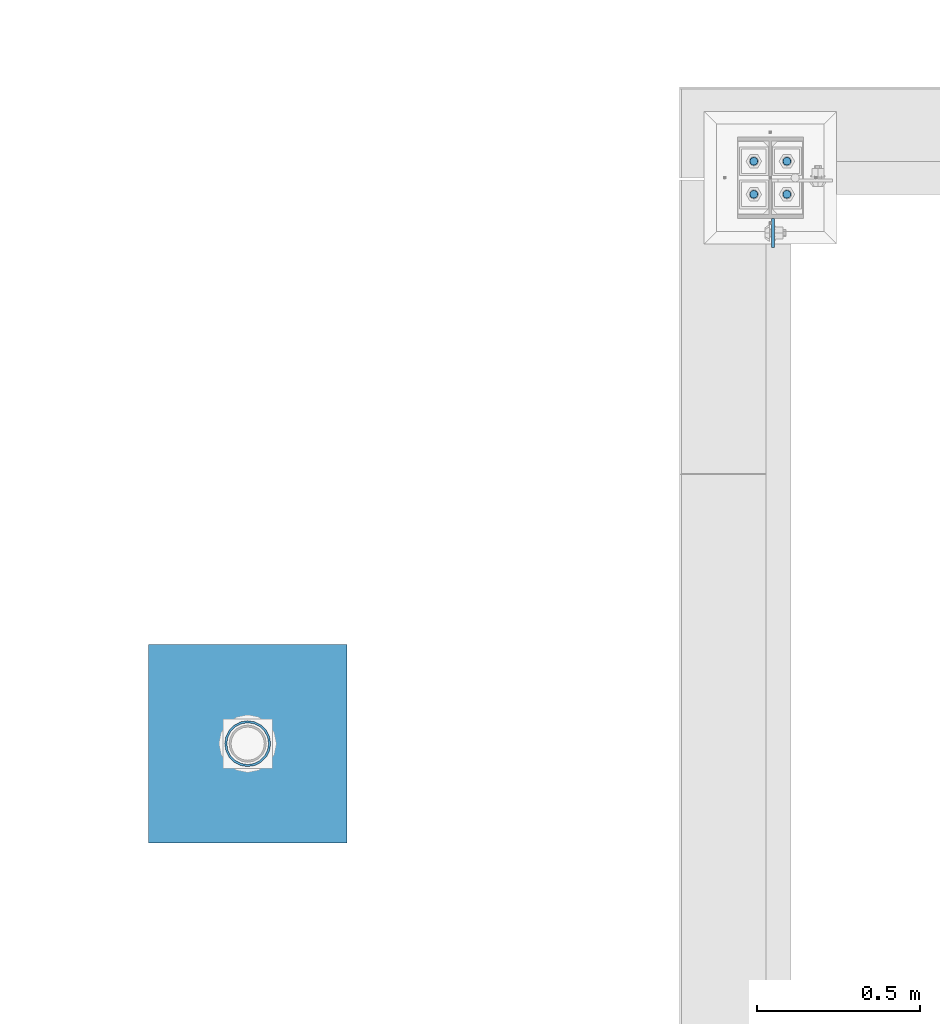
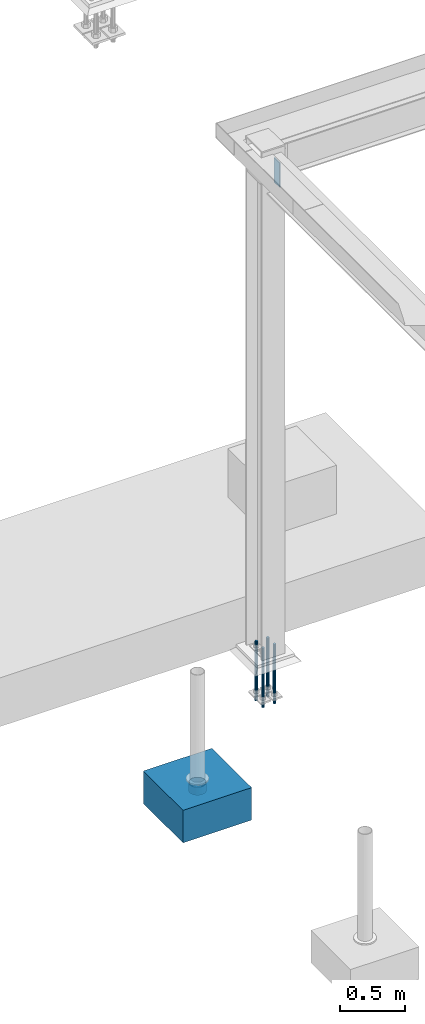
# One storey, part 1505 of 3843: 7 columns, 4 elements without a shape of their own.
"""IFC2X3 building model written with IfcOpenShell, lengths in millimetres."""

from ifc_helpers import new_model, si_unit, frame, origin_with_axes, place, context, subcontext, project, spatial, faceted_brep, material, type_object, element, aggregate, save


model = new_model("IFC2X3")

# Units and contexts
model_context = context("Model", 3, precision=1e-05, world=origin_with_axes())
body_context = subcontext(model_context, "Body", "Model", "MODEL_VIEW")
ifc_project = project(units=[si_unit("LENGTHUNIT", "METRE", prefix="MILLI"), si_unit("AREAUNIT", "SQUARE_METRE"), si_unit("VOLUMEUNIT", "CUBIC_METRE"), si_unit("MASSUNIT", "GRAM", prefix="KILO"), si_unit("TIMEUNIT", "SECOND"), si_unit("PLANEANGLEUNIT", "RADIAN"), si_unit("SOLIDANGLEUNIT", "STERADIAN"), si_unit("THERMODYNAMICTEMPERATUREUNIT", "DEGREE_CELSIUS"), si_unit("LUMINOUSINTENSITYUNIT", "LUMEN")], contexts=[model_context])

# Site, building, storey
site_placement = place(None, origin_with_axes())
site = spatial("IfcSite", under=ifc_project, at=site_placement, CompositionType="ELEMENT")
building_placement = place(site_placement, origin_with_axes())
building = spatial("IfcBuilding", under=site, at=building_placement, Name="Undefined", CompositionType="ELEMENT")
storey_placement = place(building_placement, origin_with_axes())
storey = spatial("IfcBuildingStorey", under=building, at=storey_placement, Name="Undefined", CompositionType="ELEMENT", Elevation=0.0)

# Assembly, column
assembly_1_placement = place(storey_placement, origin_with_axes())
assembly_1 = element("IfcElementAssembly", 1, at=assembly_1_placement, inside=storey, Name="PLATE", AssemblyPlace="NOTDEFINED", PredefinedType="RIGID_FRAME")
ifc_material_1 = material()
column_type_1 = type_object("IfcColumnType", Name="PIPE5SCH40", PredefinedType="NOTDEFINED")
column_1_placement = place(assembly_1_placement, frame((31617.0325124562, 32106.6249086857, 30378.4), z_axis=(-1.0, 0.0, 0.0), x_axis=(0.0, 0.0, 1.0)))
column_1 = element("IfcColumn", 2, at=column_1_placement, type_object=column_type_1, material=ifc_material_1, Name="PIPE_SLEEVE", ObjectType="PIPE5SCH40", context=body_context, shape_type="Brep", body=[
    faceted_brep([(0.0, -64.0587999999998, 0.0), (0.0, -60.9235391660477, 19.7952578392724), (76.2000000000007, -60.9235391660477, 19.7952578392724), (76.2000000000007, -64.0587999999998, 0.0), (0.0, -51.8246578392655, 37.6528179195593), (76.2000000000007, -51.8246578392655, 37.6528179195593), (0.0, -37.6528179195529, 51.8246578392718), (76.2000000000007, -37.6528179195529, 51.8246578392718), (0.0, -19.795257839266, 60.9235391660477), (76.2000000000007, -19.795257839266, 60.9235391660477), (0.0, 0.0, 64.0587999999989), (76.2000000000007, 0.0, 64.0587999999989), (0.0, 19.795257839266, 60.9235391660477), (76.2000000000007, 19.795257839266, 60.9235391660477), (0.0, 37.6528179195529, 51.8246578392718), (76.2000000000007, 37.6528179195529, 51.8246578392718), (0.0, 51.8246578392655, 37.6528179195593), (76.2000000000007, 51.8246578392655, 37.6528179195593), (0.0, 60.9235391660477, 19.7952578392724), (76.2000000000007, 60.9235391660477, 19.7952578392724), (0.0, 64.0587999999998, 0.0), (76.2000000000007, 64.0587999999998, 0.0), (0.0, 60.9235391660477, -19.7952578392724), (76.2000000000007, 60.9235391660477, -19.7952578392724), (0.0, 51.8246578392655, -37.6528179195593), (76.2000000000007, 51.8246578392655, -37.6528179195593), (0.0, 37.6528179195529, -51.8246578392718), (76.2000000000007, 37.6528179195529, -51.8246578392718), (0.0, 19.795257839266, -60.9235391660477), (76.2000000000007, 19.795257839266, -60.9235391660477), (0.0, 0.0, -64.0587999999989), (76.2000000000007, 0.0, -64.0587999999989), (0.0, -19.795257839266, -60.9235391660477), (76.2000000000007, -19.795257839266, -60.9235391660477), (0.0, -37.6528179195529, -51.8246578392718), (76.2000000000007, -37.6528179195529, -51.8246578392718), (0.0, -51.8246578392655, -37.6528179195593), (76.2000000000007, -51.8246578392655, -37.6528179195593), (0.0, -60.9235391660477, -19.7952578392724), (76.2000000000007, -60.9235391660477, -19.7952578392724), (0.0, -70.6120000000001, 0.0), (0.0, -67.1560027286332, -21.8203080068051), (76.2000000000007, -67.1560027286332, -21.8203080068051), (76.2000000000007, -70.6120000000001, 0.0), (0.0, -57.1263080068038, -41.5046922348702), (76.2000000000007, -57.1263080068038, -41.5046922348702), (0.0, -41.5046922348765, -57.126308006802), (76.2000000000007, -41.5046922348765, -57.126308006802), (0.0, -21.8203080068042, -67.1560027286323), (76.2000000000007, -21.8203080068042, -67.1560027286323), (0.0, 0.0, -70.6119999999937), (76.2000000000007, 0.0, -70.6119999999937), (0.0, 21.8203080068042, -67.1560027286323), (76.2000000000007, 21.8203080068042, -67.1560027286323), (0.0, 41.5046922348765, -57.126308006802), (76.2000000000007, 41.5046922348765, -57.126308006802), (0.0, 57.1263080068038, -41.5046922348702), (76.2000000000007, 57.1263080068038, -41.5046922348702), (0.0, 67.1560027286332, -21.8203080068051), (76.2000000000007, 67.1560027286332, -21.8203080068051), (0.0, 70.6120000000001, 0.0), (76.2000000000007, 70.6120000000001, 0.0), (0.0, 67.1560027286332, 21.8203080068051), (76.2000000000007, 67.1560027286332, 21.8203080068051), (0.0, 57.1263080068038, 41.5046922348702), (76.2000000000007, 57.1263080068038, 41.5046922348702), (0.0, 41.5046922348765, 57.126308006802), (76.2000000000007, 41.5046922348765, 57.126308006802), (0.0, 21.8203080068042, 67.1560027286323), (76.2000000000007, 21.8203080068042, 67.1560027286323), (0.0, 0.0, 70.6119999999937), (76.2000000000007, 0.0, 70.6119999999937), (0.0, -21.8203080068042, 67.1560027286323), (76.2000000000007, -21.8203080068042, 67.1560027286323), (0.0, -41.5046922348765, 57.126308006802), (76.2000000000007, -41.5046922348765, 57.126308006802), (0.0, -57.1263080068038, 41.5046922348702), (76.2000000000007, -57.1263080068038, 41.5046922348702), (0.0, -67.1560027286332, 21.8203080068051), (76.2000000000007, -67.1560027286332, 21.8203080068051)], [[[0, 1, 2, 3]], [[1, 4, 5, 2]], [[4, 6, 7, 5]], [[6, 8, 9, 7]], [[8, 10, 11, 9]], [[10, 12, 13, 11]], [[12, 14, 15, 13]], [[14, 16, 17, 15]], [[16, 18, 19, 17]], [[18, 20, 21, 19]], [[20, 22, 23, 21]], [[22, 24, 25, 23]], [[24, 26, 27, 25]], [[26, 28, 29, 27]], [[28, 30, 31, 29]], [[30, 32, 33, 31]], [[32, 34, 35, 33]], [[34, 36, 37, 35]], [[36, 38, 39, 37]], [[38, 0, 3, 39]], [[40, 41, 42, 43]], [[41, 44, 45, 42]], [[44, 46, 47, 45]], [[46, 48, 49, 47]], [[48, 50, 51, 49]], [[50, 52, 53, 51]], [[52, 54, 55, 53]], [[54, 56, 57, 55]], [[56, 58, 59, 57]], [[58, 60, 61, 59]], [[60, 62, 63, 61]], [[62, 64, 65, 63]], [[64, 66, 67, 65]], [[66, 68, 69, 67]], [[68, 70, 71, 69]], [[70, 72, 73, 71]], [[72, 74, 75, 73]], [[74, 76, 77, 75]], [[76, 78, 79, 77]], [[78, 40, 43, 79]], [[45, 47, 49, 51, 53, 55, 57, 59, 61, 63, 65, 67, 69, 71, 73, 75, 77, 79, 43, 42], [5, 7, 9, 11, 13, 15, 17, 19, 21, 23, 25, 27, 29, 31, 33, 35, 37, 39, 3, 2]], [[78, 76, 74, 72, 70, 68, 66, 64, 62, 60, 58, 56, 54, 52, 50, 48, 46, 44, 41, 40], [38, 36, 34, 32, 30, 28, 26, 24, 22, 20, 18, 16, 14, 12, 10, 8, 6, 4, 1, 0]]]),
])
aggregate(assembly_1, [column_1])

assembly_2_placement = place(storey_placement, origin_with_axes())
assembly_2 = element("IfcElementAssembly", 3, at=assembly_2_placement, inside=storey, Name="CONC_COL.", AssemblyPlace="NOTDEFINED", PredefinedType="REINFORCEMENT_UNIT")
ifc_material_2 = material(Name="CONCRETE/3000")
column_type_2 = type_object("IfcColumnType", PredefinedType="NOTDEFINED")
column_2_placement = place(assembly_2_placement, frame((31617.0325124562, 32106.6249086857, 30175.2), z_axis=(-1.0, 0.0, 0.0), x_axis=(0.0, 0.0, 1.0)))
column_2 = element("IfcColumn", 4, at=column_2_placement, type_object=column_type_2, material=ifc_material_2, Name="CONC_COL.", context=body_context, shape_type="Brep", body=[
    faceted_brep([(0.0, 304.8, -304.800000000003), (0.0, 304.8, 304.800000000003), (304.799999999999, 304.8, 304.800000000003), (304.799999999999, 304.8, -304.800000000003), (0.0, -304.8, 304.800000000003), (304.799999999999, -304.8, 304.800000000003), (0.0, -304.8, -304.800000000003), (304.799999999999, -304.8, -304.800000000003)], [[[0, 1, 2, 3]], [[1, 4, 5, 2]], [[4, 6, 7, 5]], [[6, 0, 3, 7]], [[5, 7, 3, 2]], [[6, 4, 1, 0]]]),
])
aggregate(assembly_2, [column_2])

# Assembly, columns
assembly_3_placement = place(storey_placement, origin_with_axes())
assembly_3 = element("IfcElementAssembly", 5, at=assembly_3_placement, inside=storey, Name="TEMPLATE", AssemblyPlace="NOTDEFINED", PredefinedType="RIGID_FRAME")
ifc_material_3 = material(Name="Undefined/F1554-GR.55")
column_type_3 = type_object("IfcColumnType", PredefinedType="NOTDEFINED")
column_3_placement = place(assembly_3_placement, frame((33172.4, 33794.7, 30022.8), z_axis=(0.0, -1.0, 0.0), x_axis=(0.0, 0.0, -1.0)))
column_3 = element("IfcColumn", 6, at=column_3_placement, type_object=column_type_3, material=ifc_material_3, Name="ANCHOR_ROD", context=body_context, shape_type="Brep", body=[
    faceted_brep([(-127.0, -10.3923048454162, 6.0), (-127.0, -6.0, 10.3923048454126), (-127.0, 0.0, 12.0), (-127.0, 6.0, 10.3923048454126), (-127.0, 10.3923048454162, 6.0), (-127.0, 12.0, 0.0), (-127.0, 10.3923048454162, -6.0), (-127.0, 6.0, -10.3923048454126), (-127.0, 0.0, -12.0), (-127.0, -6.0, -10.3923048454126), (-127.0, -10.3923048454162, -6.0), (-127.0, -12.0, 0.0), (0.0, 12.0, 0.0), (0.0, 10.3923048454162, -6.0), (0.0, 6.0, -10.3923048454126), (0.0, 0.0, -12.0), (0.0, -6.0, -10.3923048454126), (0.0, -10.3923048454162, -6.0), (0.0, -12.0, 0.0), (0.0, -10.3923048454162, 6.0), (0.0, -6.0, 10.3923048454126), (0.0, 0.0, 12.0), (0.0, 6.0, 10.3923048454126), (0.0, 10.3923048454162, 6.0), (0.0, -10.9985226280696, 6.34999999999854), (0.0, -6.35000000000582, 10.9985226280623), (0.0, 0.0, 12.6999999999971), (0.0, 6.35000000000582, 10.9985226280623), (0.0, 10.9985226280696, 6.34999999999854), (0.0, 12.6999999999971, 0.0), (0.0, 10.9985226280696, -6.34999999999854), (0.0, 6.35000000000582, -10.9985226280623), (0.0, 0.0, -12.6999999999971), (0.0, -6.35000000000582, -10.9985226280623), (0.0, -10.9985226280696, -6.34999999999854), (0.0, -12.6999999999971, 0.0), (304.799999999999, -12.6999999999971, 0.0), (304.799999999999, -10.9985226280623, 6.35000000000036), (304.799999999999, -6.34999999999854, 10.9985226280623), (304.799999999999, 0.0, 12.7000000000007), (304.799999999999, 6.34999999999854, 10.9985226280623), (304.799999999999, 10.9985226280623, 6.35000000000036), (304.799999999999, 12.6999999999971, 0.0), (304.799999999999, 10.9985226280623, -6.35000000000036), (304.799999999999, 6.34999999999854, -10.9985226280623), (304.799999999999, 0.0, -12.7000000000007), (304.799999999999, -6.34999999999854, -10.9985226280623), (304.799999999999, -10.9985226280623, -6.35000000000036), (304.799999999999, -6.0, 10.3923048454126), (304.799999999999, 0.0, 12.0), (304.799999999999, 6.0, 10.3923048454126), (304.799999999999, 10.3923048454162, 6.0), (304.799999999999, 12.0, 0.0), (304.799999999999, 10.3923048454162, -6.0), (304.799999999999, 6.0, -10.3923048454126), (304.799999999999, 0.0, -12.0), (304.799999999999, -6.0, -10.3923048454126), (304.799999999999, -10.3923048454162, -6.0), (304.799999999999, -12.0, 0.0), (304.799999999999, -10.3923048454162, 6.0), (431.799999999999, -6.0, -10.3923048454126), (431.799999999999, 0.0, -12.0), (431.799999999999, 6.0, -10.3923048454126), (431.799999999999, 10.3923048454162, -6.0), (431.799999999999, 12.0, 0.0), (431.799999999999, 10.3923048454162, 6.0), (431.799999999999, 6.0, 10.3923048454126), (431.799999999999, 0.0, 12.0), (431.799999999999, -6.0, 10.3923048454126), (431.799999999999, -10.3923048454162, 6.0), (431.799999999999, -12.0, 0.0), (431.799999999999, -10.3923048454162, -6.0)], [[[0, 1, 2, 3, 4, 5, 6, 7, 8, 9, 10, 11]], [[6, 5, 12, 13]], [[7, 6, 13, 14]], [[8, 7, 14, 15]], [[9, 8, 15, 16]], [[10, 9, 16, 17]], [[11, 10, 17, 18]], [[0, 11, 18, 19]], [[1, 0, 19, 20]], [[2, 1, 20, 21]], [[3, 2, 21, 22]], [[4, 3, 22, 23]], [[5, 4, 23, 12]], [[24, 25, 26, 27, 28, 29, 30, 31, 32, 33, 34, 35], [22, 21, 20, 19, 18, 17, 16, 15, 14, 13, 12, 23]], [[24, 35, 36, 37]], [[25, 24, 37, 38]], [[26, 25, 38, 39]], [[27, 26, 39, 40]], [[28, 27, 40, 41]], [[29, 28, 41, 42]], [[30, 29, 42, 43]], [[31, 30, 43, 44]], [[32, 31, 44, 45]], [[33, 32, 45, 46]], [[34, 33, 46, 47]], [[35, 34, 47, 36]], [[46, 45, 44, 43, 42, 41, 40, 39, 38, 37, 36, 47], [48, 49, 50, 51, 52, 53, 54, 55, 56, 57, 58, 59]], [[60, 61, 62, 63, 64, 65, 66, 67, 68, 69, 70, 71]], [[68, 67, 49, 48]], [[69, 68, 48, 59]], [[70, 69, 59, 58]], [[71, 70, 58, 57]], [[60, 71, 57, 56]], [[61, 60, 56, 55]], [[62, 61, 55, 54]], [[63, 62, 54, 53]], [[64, 63, 53, 52]], [[65, 64, 52, 51]], [[66, 65, 51, 50]], [[67, 66, 50, 49]]]),
])
column_4_placement = place(assembly_3_placement, frame((33274.0, 33794.7, 30022.8), z_axis=(0.0, 1.0, 0.0), x_axis=(0.0, 0.0, -1.0)))
column_4 = element("IfcColumn", 7, at=column_4_placement, type_object=column_type_3, material=ifc_material_3, Name="ANCHOR_ROD", context=body_context, shape_type="Brep", body=[
    faceted_brep([(-127.0, -10.3923048454162, 6.0), (-127.0, -6.0, 10.3923048454126), (-127.0, 0.0, 12.0), (-127.0, 6.0, 10.3923048454126), (-127.0, 10.3923048454162, 6.0), (-127.0, 12.0, 0.0), (-127.0, 10.3923048454162, -6.0), (-127.0, 6.0, -10.3923048454126), (-127.0, 0.0, -12.0), (-127.0, -6.0, -10.3923048454126), (-127.0, -10.3923048454162, -6.0), (-127.0, -12.0, 0.0), (0.0, 12.0, 0.0), (0.0, 10.3923048454162, -6.0), (0.0, 6.0, -10.3923048454126), (0.0, 0.0, -12.0), (0.0, -6.0, -10.3923048454126), (0.0, -10.3923048454162, -6.0), (0.0, -12.0, 0.0), (0.0, -10.3923048454162, 6.0), (0.0, -6.0, 10.3923048454126), (0.0, 0.0, 12.0), (0.0, 6.0, 10.3923048454126), (0.0, 10.3923048454162, 6.0), (0.0, -10.9985226280696, 6.34999999999854), (0.0, -6.35000000000582, 10.9985226280623), (0.0, 0.0, 12.6999999999971), (0.0, 6.35000000000582, 10.9985226280623), (0.0, 10.9985226280696, 6.34999999999854), (0.0, 12.6999999999971, 0.0), (0.0, 10.9985226280696, -6.34999999999854), (0.0, 6.35000000000582, -10.9985226280623), (0.0, 0.0, -12.6999999999971), (0.0, -6.35000000000582, -10.9985226280623), (0.0, -10.9985226280696, -6.34999999999854), (0.0, -12.6999999999971, 0.0), (304.799999999999, -12.6999999999971, 0.0), (304.799999999999, -10.9985226280623, 6.35000000000036), (304.799999999999, -6.34999999999854, 10.9985226280623), (304.799999999999, 0.0, 12.7000000000007), (304.799999999999, 6.34999999999854, 10.9985226280623), (304.799999999999, 10.9985226280623, 6.35000000000036), (304.799999999999, 12.6999999999971, 0.0), (304.799999999999, 10.9985226280623, -6.35000000000036), (304.799999999999, 6.34999999999854, -10.9985226280623), (304.799999999999, 0.0, -12.7000000000007), (304.799999999999, -6.34999999999854, -10.9985226280623), (304.799999999999, -10.9985226280623, -6.35000000000036), (304.799999999999, -6.0, 10.3923048454126), (304.799999999999, 0.0, 12.0), (304.799999999999, 6.0, 10.3923048454126), (304.799999999999, 10.3923048454162, 6.0), (304.799999999999, 12.0, 0.0), (304.799999999999, 10.3923048454162, -6.0), (304.799999999999, 6.0, -10.3923048454126), (304.799999999999, 0.0, -12.0), (304.799999999999, -6.0, -10.3923048454126), (304.799999999999, -10.3923048454162, -6.0), (304.799999999999, -12.0, 0.0), (304.799999999999, -10.3923048454162, 6.0), (431.799999999999, -6.0, -10.3923048454126), (431.799999999999, 0.0, -12.0), (431.799999999999, 6.0, -10.3923048454126), (431.799999999999, 10.3923048454162, -6.0), (431.799999999999, 12.0, 0.0), (431.799999999999, 10.3923048454162, 6.0), (431.799999999999, 6.0, 10.3923048454126), (431.799999999999, 0.0, 12.0), (431.799999999999, -6.0, 10.3923048454126), (431.799999999999, -10.3923048454162, 6.0), (431.799999999999, -12.0, 0.0), (431.799999999999, -10.3923048454162, -6.0)], [[[0, 1, 2, 3, 4, 5, 6, 7, 8, 9, 10, 11]], [[6, 5, 12, 13]], [[7, 6, 13, 14]], [[8, 7, 14, 15]], [[9, 8, 15, 16]], [[10, 9, 16, 17]], [[11, 10, 17, 18]], [[0, 11, 18, 19]], [[1, 0, 19, 20]], [[2, 1, 20, 21]], [[3, 2, 21, 22]], [[4, 3, 22, 23]], [[5, 4, 23, 12]], [[24, 25, 26, 27, 28, 29, 30, 31, 32, 33, 34, 35], [22, 21, 20, 19, 18, 17, 16, 15, 14, 13, 12, 23]], [[24, 35, 36, 37]], [[25, 24, 37, 38]], [[26, 25, 38, 39]], [[27, 26, 39, 40]], [[28, 27, 40, 41]], [[29, 28, 41, 42]], [[30, 29, 42, 43]], [[31, 30, 43, 44]], [[32, 31, 44, 45]], [[33, 32, 45, 46]], [[34, 33, 46, 47]], [[35, 34, 47, 36]], [[46, 45, 44, 43, 42, 41, 40, 39, 38, 37, 36, 47], [48, 49, 50, 51, 52, 53, 54, 55, 56, 57, 58, 59]], [[60, 61, 62, 63, 64, 65, 66, 67, 68, 69, 70, 71]], [[68, 67, 49, 48]], [[69, 68, 48, 59]], [[70, 69, 59, 58]], [[71, 70, 58, 57]], [[60, 71, 57, 56]], [[61, 60, 56, 55]], [[62, 61, 55, 54]], [[63, 62, 54, 53]], [[64, 63, 53, 52]], [[65, 64, 52, 51]], [[66, 65, 51, 50]], [[67, 66, 50, 49]]]),
])
column_5_placement = place(assembly_3_placement, frame((33172.4, 33896.3, 30022.8), z_axis=(0.0, -1.0, 0.0), x_axis=(0.0, 0.0, -1.0)))
column_5 = element("IfcColumn", 8, at=column_5_placement, type_object=column_type_3, material=ifc_material_3, Name="ANCHOR_ROD", context=body_context, shape_type="Brep", body=[
    faceted_brep([(-127.0, -10.3923048454162, 6.0), (-127.0, -6.0, 10.3923048454126), (-127.0, 0.0, 12.0), (-127.0, 6.0, 10.3923048454126), (-127.0, 10.3923048454162, 6.0), (-127.0, 12.0, 0.0), (-127.0, 10.3923048454162, -6.0), (-127.0, 6.0, -10.3923048454126), (-127.0, 0.0, -12.0), (-127.0, -6.0, -10.3923048454126), (-127.0, -10.3923048454162, -6.0), (-127.0, -12.0, 0.0), (0.0, 12.0, 0.0), (0.0, 10.3923048454162, -6.0), (0.0, 6.0, -10.3923048454126), (0.0, 0.0, -12.0), (0.0, -6.0, -10.3923048454126), (0.0, -10.3923048454162, -6.0), (0.0, -12.0, 0.0), (0.0, -10.3923048454162, 6.0), (0.0, -6.0, 10.3923048454126), (0.0, 0.0, 12.0), (0.0, 6.0, 10.3923048454126), (0.0, 10.3923048454162, 6.0), (0.0, -10.9985226280696, 6.34999999999854), (0.0, -6.35000000000582, 10.9985226280623), (0.0, 0.0, 12.6999999999971), (0.0, 6.35000000000582, 10.9985226280623), (0.0, 10.9985226280696, 6.34999999999854), (0.0, 12.6999999999971, 0.0), (0.0, 10.9985226280696, -6.34999999999854), (0.0, 6.35000000000582, -10.9985226280623), (0.0, 0.0, -12.6999999999971), (0.0, -6.35000000000582, -10.9985226280623), (0.0, -10.9985226280696, -6.34999999999854), (0.0, -12.6999999999971, 0.0), (304.799999999999, -12.6999999999971, 0.0), (304.799999999999, -10.9985226280623, 6.35000000000036), (304.799999999999, -6.34999999999854, 10.9985226280623), (304.799999999999, 0.0, 12.7000000000007), (304.799999999999, 6.34999999999854, 10.9985226280623), (304.799999999999, 10.9985226280623, 6.35000000000036), (304.799999999999, 12.6999999999971, 0.0), (304.799999999999, 10.9985226280623, -6.35000000000036), (304.799999999999, 6.34999999999854, -10.9985226280623), (304.799999999999, 0.0, -12.7000000000007), (304.799999999999, -6.34999999999854, -10.9985226280623), (304.799999999999, -10.9985226280623, -6.35000000000036), (304.799999999999, -6.0, 10.3923048454126), (304.799999999999, 0.0, 12.0), (304.799999999999, 6.0, 10.3923048454126), (304.799999999999, 10.3923048454162, 6.0), (304.799999999999, 12.0, 0.0), (304.799999999999, 10.3923048454162, -6.0), (304.799999999999, 6.0, -10.3923048454126), (304.799999999999, 0.0, -12.0), (304.799999999999, -6.0, -10.3923048454126), (304.799999999999, -10.3923048454162, -6.0), (304.799999999999, -12.0, 0.0), (304.799999999999, -10.3923048454162, 6.0), (431.799999999999, -6.0, -10.3923048454126), (431.799999999999, 0.0, -12.0), (431.799999999999, 6.0, -10.3923048454126), (431.799999999999, 10.3923048454162, -6.0), (431.799999999999, 12.0, 0.0), (431.799999999999, 10.3923048454162, 6.0), (431.799999999999, 6.0, 10.3923048454126), (431.799999999999, 0.0, 12.0), (431.799999999999, -6.0, 10.3923048454126), (431.799999999999, -10.3923048454162, 6.0), (431.799999999999, -12.0, 0.0), (431.799999999999, -10.3923048454162, -6.0)], [[[0, 1, 2, 3, 4, 5, 6, 7, 8, 9, 10, 11]], [[6, 5, 12, 13]], [[7, 6, 13, 14]], [[8, 7, 14, 15]], [[9, 8, 15, 16]], [[10, 9, 16, 17]], [[11, 10, 17, 18]], [[0, 11, 18, 19]], [[1, 0, 19, 20]], [[2, 1, 20, 21]], [[3, 2, 21, 22]], [[4, 3, 22, 23]], [[5, 4, 23, 12]], [[24, 25, 26, 27, 28, 29, 30, 31, 32, 33, 34, 35], [22, 21, 20, 19, 18, 17, 16, 15, 14, 13, 12, 23]], [[24, 35, 36, 37]], [[25, 24, 37, 38]], [[26, 25, 38, 39]], [[27, 26, 39, 40]], [[28, 27, 40, 41]], [[29, 28, 41, 42]], [[30, 29, 42, 43]], [[31, 30, 43, 44]], [[32, 31, 44, 45]], [[33, 32, 45, 46]], [[34, 33, 46, 47]], [[35, 34, 47, 36]], [[46, 45, 44, 43, 42, 41, 40, 39, 38, 37, 36, 47], [48, 49, 50, 51, 52, 53, 54, 55, 56, 57, 58, 59]], [[60, 61, 62, 63, 64, 65, 66, 67, 68, 69, 70, 71]], [[68, 67, 49, 48]], [[69, 68, 48, 59]], [[70, 69, 59, 58]], [[71, 70, 58, 57]], [[60, 71, 57, 56]], [[61, 60, 56, 55]], [[62, 61, 55, 54]], [[63, 62, 54, 53]], [[64, 63, 53, 52]], [[65, 64, 52, 51]], [[66, 65, 51, 50]], [[67, 66, 50, 49]]]),
])
column_6_placement = place(assembly_3_placement, frame((33274.0, 33896.3, 30022.8), z_axis=(0.0, 1.0, 0.0), x_axis=(0.0, 0.0, -1.0)))
column_6 = element("IfcColumn", 9, at=column_6_placement, type_object=column_type_3, material=ifc_material_3, Name="ANCHOR_ROD", context=body_context, shape_type="Brep", body=[
    faceted_brep([(-127.0, -10.3923048454162, 6.0), (-127.0, -6.0, 10.3923048454126), (-127.0, 0.0, 12.0), (-127.0, 6.0, 10.3923048454126), (-127.0, 10.3923048454162, 6.0), (-127.0, 12.0, 0.0), (-127.0, 10.3923048454162, -6.0), (-127.0, 6.0, -10.3923048454126), (-127.0, 0.0, -12.0), (-127.0, -6.0, -10.3923048454126), (-127.0, -10.3923048454162, -6.0), (-127.0, -12.0, 0.0), (0.0, 12.0, 0.0), (0.0, 10.3923048454162, -6.0), (0.0, 6.0, -10.3923048454126), (0.0, 0.0, -12.0), (0.0, -6.0, -10.3923048454126), (0.0, -10.3923048454162, -6.0), (0.0, -12.0, 0.0), (0.0, -10.3923048454162, 6.0), (0.0, -6.0, 10.3923048454126), (0.0, 0.0, 12.0), (0.0, 6.0, 10.3923048454126), (0.0, 10.3923048454162, 6.0), (0.0, -10.9985226280696, 6.34999999999854), (0.0, -6.35000000000582, 10.9985226280623), (0.0, 0.0, 12.6999999999971), (0.0, 6.35000000000582, 10.9985226280623), (0.0, 10.9985226280696, 6.34999999999854), (0.0, 12.6999999999971, 0.0), (0.0, 10.9985226280696, -6.34999999999854), (0.0, 6.35000000000582, -10.9985226280623), (0.0, 0.0, -12.6999999999971), (0.0, -6.35000000000582, -10.9985226280623), (0.0, -10.9985226280696, -6.34999999999854), (0.0, -12.6999999999971, 0.0), (304.799999999999, -12.6999999999971, 0.0), (304.799999999999, -10.9985226280623, 6.35000000000036), (304.799999999999, -6.34999999999854, 10.9985226280623), (304.799999999999, 0.0, 12.7000000000007), (304.799999999999, 6.34999999999854, 10.9985226280623), (304.799999999999, 10.9985226280623, 6.35000000000036), (304.799999999999, 12.6999999999971, 0.0), (304.799999999999, 10.9985226280623, -6.35000000000036), (304.799999999999, 6.34999999999854, -10.9985226280623), (304.799999999999, 0.0, -12.7000000000007), (304.799999999999, -6.34999999999854, -10.9985226280623), (304.799999999999, -10.9985226280623, -6.35000000000036), (304.799999999999, -6.0, 10.3923048454126), (304.799999999999, 0.0, 12.0), (304.799999999999, 6.0, 10.3923048454126), (304.799999999999, 10.3923048454162, 6.0), (304.799999999999, 12.0, 0.0), (304.799999999999, 10.3923048454162, -6.0), (304.799999999999, 6.0, -10.3923048454126), (304.799999999999, 0.0, -12.0), (304.799999999999, -6.0, -10.3923048454126), (304.799999999999, -10.3923048454162, -6.0), (304.799999999999, -12.0, 0.0), (304.799999999999, -10.3923048454162, 6.0), (431.799999999999, -6.0, -10.3923048454126), (431.799999999999, 0.0, -12.0), (431.799999999999, 6.0, -10.3923048454126), (431.799999999999, 10.3923048454162, -6.0), (431.799999999999, 12.0, 0.0), (431.799999999999, 10.3923048454162, 6.0), (431.799999999999, 6.0, 10.3923048454126), (431.799999999999, 0.0, 12.0), (431.799999999999, -6.0, 10.3923048454126), (431.799999999999, -10.3923048454162, 6.0), (431.799999999999, -12.0, 0.0), (431.799999999999, -10.3923048454162, -6.0)], [[[0, 1, 2, 3, 4, 5, 6, 7, 8, 9, 10, 11]], [[6, 5, 12, 13]], [[7, 6, 13, 14]], [[8, 7, 14, 15]], [[9, 8, 15, 16]], [[10, 9, 16, 17]], [[11, 10, 17, 18]], [[0, 11, 18, 19]], [[1, 0, 19, 20]], [[2, 1, 20, 21]], [[3, 2, 21, 22]], [[4, 3, 22, 23]], [[5, 4, 23, 12]], [[24, 25, 26, 27, 28, 29, 30, 31, 32, 33, 34, 35], [22, 21, 20, 19, 18, 17, 16, 15, 14, 13, 12, 23]], [[24, 35, 36, 37]], [[25, 24, 37, 38]], [[26, 25, 38, 39]], [[27, 26, 39, 40]], [[28, 27, 40, 41]], [[29, 28, 41, 42]], [[30, 29, 42, 43]], [[31, 30, 43, 44]], [[32, 31, 44, 45]], [[33, 32, 45, 46]], [[34, 33, 46, 47]], [[35, 34, 47, 36]], [[46, 45, 44, 43, 42, 41, 40, 39, 38, 37, 36, 47], [48, 49, 50, 51, 52, 53, 54, 55, 56, 57, 58, 59]], [[60, 61, 62, 63, 64, 65, 66, 67, 68, 69, 70, 71]], [[68, 67, 49, 48]], [[69, 68, 48, 59]], [[70, 69, 59, 58]], [[71, 70, 58, 57]], [[60, 71, 57, 56]], [[61, 60, 56, 55]], [[62, 61, 55, 54]], [[63, 62, 54, 53]], [[64, 63, 53, 52]], [[65, 64, 52, 51]], [[66, 65, 51, 50]], [[67, 66, 50, 49]]]),
])
aggregate(assembly_3, [column_3, column_4, column_5, column_6])

# Assembly, column
assembly_4_placement = place(storey_placement, origin_with_axes())
assembly_4 = element("IfcElementAssembly", 10, at=assembly_4_placement, inside=storey, Name="COLUMN", AssemblyPlace="NOTDEFINED", PredefinedType="RIGID_FRAME")
ifc_material_4 = material(Name="STEEL/A572-50")
column_type_4 = type_object("IfcColumnType", PredefinedType="NOTDEFINED")
column_7_placement = place(assembly_4_placement, frame((33231.1374999523, 33675.6375, 34544.0), z_axis=(0.0, 1.0, 0.0), x_axis=(0.0, 0.0, 1.0)))
column_7 = element("IfcColumn", 11, at=column_7_placement, type_object=column_type_4, material=ifc_material_4, Name="PLATE", context=body_context, shape_type="Brep", body=[
    faceted_brep([(0.0, 4.76249999999709, -44.4500000000007), (0.0, 4.76249999999709, 44.4500000000007), (228.599999999999, 4.76249999999709, 44.4500000000007), (228.599999999999, 4.76249999999709, -44.4500000000007), (0.0, -4.76249999999709, 44.4500000000007), (228.599999999999, -4.76249999999709, 44.4500000000007), (0.0, -4.76249999999709, -44.4500000000007), (228.599999999999, -4.76249999999709, -44.4500000000007)], [[[0, 1, 2, 3]], [[1, 4, 5, 2]], [[4, 6, 7, 5]], [[6, 0, 3, 7]], [[5, 7, 3, 2]], [[6, 4, 1, 0]]]),
])
aggregate(assembly_4, [column_7])

save(model, "model.ifc")
